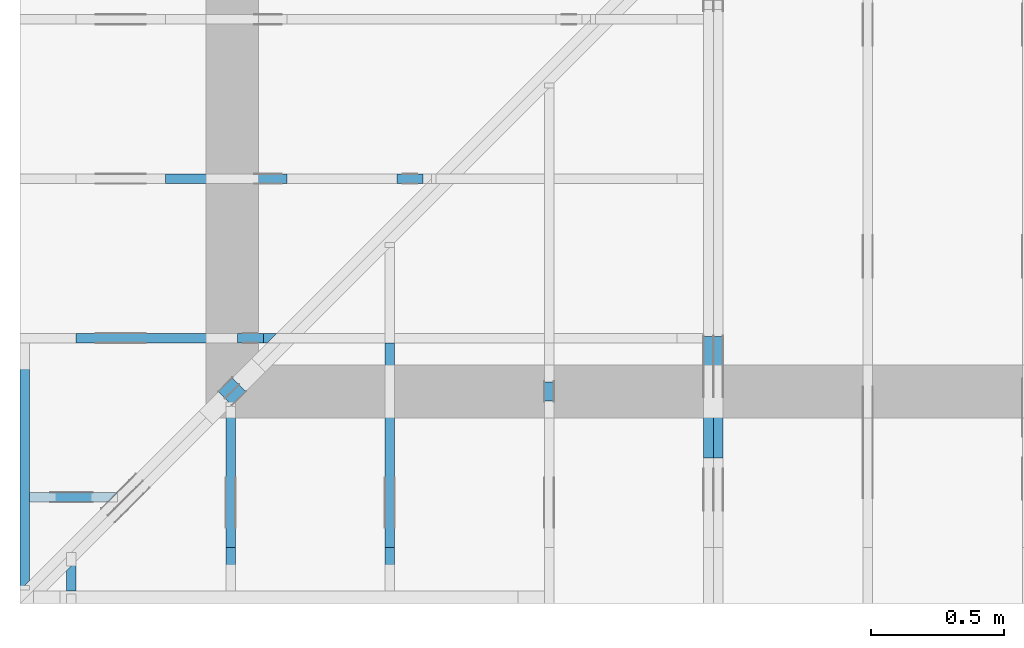
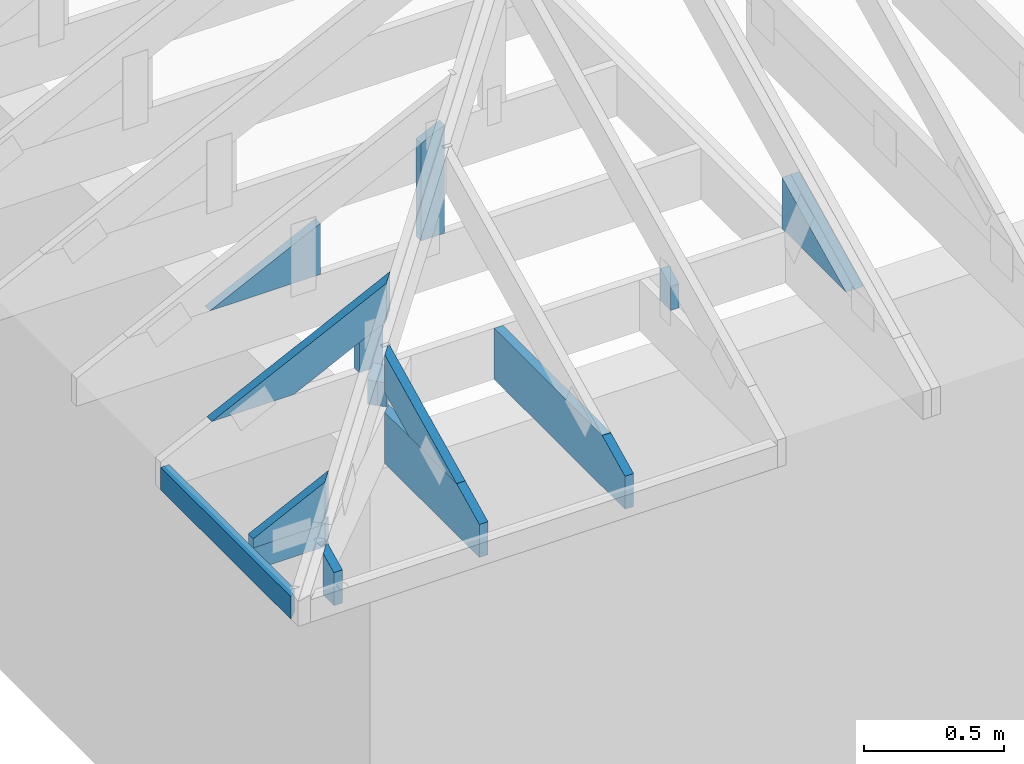
# One storey, part 41 of 159: 16 members, 10 elements without a shape of their own.
"""IFC2X3 building model written with IfcOpenShell, lengths in millimetres."""

from ifc_helpers import new_model, si_unit, frame, origin, origin_with_axes, origin_2d, place, context, project, spatial, faceted_brep, element, aggregate, save


model = new_model("IFC2X3")

# Units and contexts
model_context = context("Model", 3, precision=1e-05, world=origin())
plan_context = context("Plan", 2, precision=1e-05, world=origin_2d())
ifc_project = project(units=[si_unit("LENGTHUNIT", "METRE", prefix="MILLI"), si_unit("AREAUNIT", "SQUARE_METRE"), si_unit("VOLUMEUNIT", "CUBIC_METRE"), si_unit("SOLIDANGLEUNIT", "STERADIAN"), si_unit("PLANEANGLEUNIT", "RADIAN"), si_unit("MASSUNIT", "GRAM"), si_unit("TIMEUNIT", "SECOND"), si_unit("THERMODYNAMICTEMPERATUREUNIT", "DEGREE_CELSIUS"), si_unit("LUMINOUSINTENSITYUNIT", "LUMEN")], contexts=[model_context, plan_context])

# Site, building, storey
site_placement = place(None, origin_with_axes())
site = spatial("IfcSite", under=ifc_project, at=site_placement, CompositionType="ELEMENT")
building_placement = place(site_placement, origin_with_axes())
building = spatial("IfcBuilding", under=site, at=building_placement, Name="Plan 1", CompositionType="ELEMENT")
storey_placement = place(building_placement, origin_with_axes())
storey = spatial("IfcBuildingStorey", under=building, at=storey_placement, Name="Etasje 1", CompositionType="ELEMENT", Elevation=0.0)

# Assembly, member
assembly_1_placement = place(storey_placement, frame((-700.0000000000088, 282.0074014212605, 0.0), z_axis=(-1.0, 2.1499973025876362e-14, 6.123031769111886e-17), x_axis=(-2.1499973025876362e-14, -1.0, 0.0)))
assembly_1 = element("IfcElementAssembly", 1, at=assembly_1_placement, inside=storey, Name="uu2 (1)", AssemblyPlace="FACTORY", PredefinedType="TRUSS")
member_1_placement = place(assembly_1_placement, frame((931.0946655273438, 98.00000236466238, -36.00000106976029), z_axis=(0.0, 0.0, 1.0), x_axis=(-1.0, 1.2246063538223773e-16, 0.0)))
member_1 = element("IfcMember", 2, at=member_1_placement, Name="uu2-U53", context=model_context, shape_type="Brep", body=[
    faceted_brep([(36.00002329176911, 2.3646623104379705e-06, -2.842170943040401e-14), (2.2222008851713326e-05, 2.3646623787954017e-06, 36.00000106976023), (2.222200897250559e-05, 98.00000236466238, 36.0000010697603), (36.00002329176915, 98.00000236466232, 1.1368683772161603e-13), (931.0946877493527, 2.364662207761731e-06, 1.0697602874643055e-06), (931.0946877493527, 2.364662225953234e-06, 36.00000106976029), (2.2222008965400164e-05, 2.3646623969869005e-06, 36.00000106976029), (36.000022222008965, 2.364662372182523e-06, 1.0697602874643055e-06), (36.000022222011125, 98.00000236466238, 1.069760291872891e-06), (931.0946877493548, 98.00000236466238, 1.0697604014867523e-06), (931.0946877493548, 2.364662492482239e-06, 1.0697604014867523e-06), (36.00002222201101, 2.364662492482239e-06, 1.069760291872891e-06), (2.222201112545008e-05, 98.00000236466238, 36.00000106976029), (931.0946877493549, 98.00000236466232, 36.00000106976029), (931.0946877493549, 98.00000236466232, 1.0697602874643053e-06), (36.000022222011125, 98.00000236466238, 1.0697602874643053e-06), (931.0946655273438, 98.0000023463934, 2.0347285101252055e-06), (931.0946655273438, 98.0000023463934, 36.00000106976029), (931.0946655273438, 0.0, 36.000002896668946), (931.0946655273438, 0.0, 3.532793598992612e-06), (931.0946655273438, 98.00000236466249, 36.00000106976029), (0.0, 98.00000236466249, 36.00000106976029), (0.0, 2.364662393006256e-06, 36.00000106976029), (931.0946655273438, 2.364662393006256e-06, 36.00000106976029)], [[[0, 1, 2, 3]], [[4, 5, 6, 7]], [[8, 9, 10, 11]], [[12, 13, 14, 15]], [[16, 17, 18, 19]], [[20, 21, 22, 23]]]),
])
aggregate(assembly_1, [member_1])

# Assembly, members
assembly_2_placement = place(storey_placement, frame((-664.0000000000214, -317.99259857873943, 1.1021457184401395e-15), z_axis=(0.0, -1.0, 6.123031769111886e-17), x_axis=(1.0, 0.0, 0.0)))
assembly_2 = element("IfcElementAssembly", 3, at=assembly_2_placement, inside=storey, Name="S9 (106)", AssemblyPlace="FACTORY", PredefinedType="TRUSS")
member_2_placement = place(assembly_2_placement, frame((49.292707424058904, -3.0650545701473186, -36.000001130761554), z_axis=(0.0, 0.0, 1.0), x_axis=(0.8987940462991673, 0.43837114678907735, 0.0)))
member_2 = element("IfcMember", 4, at=member_2_placement, Name="S9-O79", context=model_context, shape_type="Brep", body=[
    faceted_brep([(385.7178019391226, 148.00000083082443, 3.1665292681282153e-06), (345.6641349417873, 147.9999951378864, 35.999998100575525), (273.4797109907065, 3.211798116353748e-07, 36.00000113076159), (313.5333809332368, -2.1316282072803006e-14, 9.131758815783542e-07), (17.34125812148463, 148.00000032034563, 1.130761553724824e-06), (17.34125812148463, 148.0000003203457, 36.000001130761554), (345.66413409804716, 148.00000032034566, 36.000001130761554), (385.7178030738772, 148.0000003203456, 1.130761553724824e-06), (1.2395862583503003e-05, 112.44517100735109, 1.2340157908852234e-06), (1.2395862583503003e-05, 112.44517100735109, 36.00000113076156), (17.341261635190712, 148.00000094052962, 36.00000085956592), (17.341261635190712, 148.00000094052962, 7.888609052210118e-31), (230.54677531017086, 3.214345412061448e-07, 1.130761553724824e-06), (230.54677531017086, 3.214345412061448e-07, 36.000001130761554), (1.3192543747209129e-05, 112.44516939454279, 36.000001130761554), (1.3192543747209129e-05, 112.44516939454279, 1.130761553724824e-06), (313.5333808476825, 3.2094196696327795e-07, 1.130761553724824e-06), (273.4797118718524, 3.209419845186718e-07, 36.000001130761554), (230.54677806447938, 3.209419924050633e-07, 36.000001130761554), (230.54677806447938, 3.209419822071661e-07, 1.130761553724824e-06), (345.6641363447104, 148.0000003211798, 36.000001130761554), (17.341252738753383, 148.0000003211798, 36.000001130761554), (5.180159625695069e-06, 112.44516786268372, 36.000001130761554), (230.54677718333346, 3.214346548929825e-07, 36.000001130761554), (273.4797109907065, 3.214346548929825e-07, 36.000001130761554), (17.34124755859377, 148.00000032137, 1.1307615558484441e-06), (385.7178039550782, 148.00000032137, 1.1307616009600713e-06), (313.5333786010743, 3.202207068397911e-07, 1.1307615921203207e-06), (230.54676818847656, 3.202207068397911e-07, 1.1307615819577276e-06), (0.0, 112.4451716764219, 1.130761553724824e-06)], [[[0, 1, 2, 3]], [[4, 5, 6, 7]], [[8, 9, 10, 11]], [[12, 13, 14, 15]], [[16, 17, 18, 19]], [[20, 21, 22, 23, 24]], [[25, 26, 27, 28, 29]]]),
])
member_3_placement = place(assembly_2_placement, frame((331.09464437508007, 98.00000236466187, -36.000001069767535), z_axis=(0.0, 0.0, 1.0), x_axis=(-1.0, 1.898817474782488e-15, 0.0)))
member_3 = element("IfcMember", 5, at=member_3_placement, Name="S9-U56", context=model_context, shape_type="Brep", body=[
    faceted_brep([(2.2609328924537968e-14, 2.364661862731428e-06, -2.2609328924528657e-14), (36.00000106975323, 2.364661938258905e-06, 36.000001069767535), (36.00000106975305, 98.00000236466194, 36.00000106976755), (4.060030872416688e-14, 98.00000236466187, 2.0098422143426072e-13), (331.09463607951886, 2.3646618916506707e-06, 1.06976753500021e-06), (331.09463607951886, 2.3646618778677506e-06, 36.000001069767535), (36.00000106975324, 2.3646619320739654e-06, 36.000001069767535), (1.0697532388803666e-06, 2.36466195246976e-06, 1.06976753500021e-06), (1.0697676202653383e-06, 98.00000236466187, 1.06976753500021e-06), (36.00000106976762, 98.00000236466187, 36.000001069767535), (331.09463607953325, 98.00000236466184, 36.000001069767535), (331.09463607953325, 98.00000236466185, 1.06976753500021e-06), (331.09464437508007, 98.0000023463934, 2.0347357576611103e-06), (331.09464437508007, 98.0000023463934, 36.000001069767535), (331.09464437508007, 0.0, 36.00000289667619), (331.09464437508007, 0.0, 3.5328008465285166e-06), (331.0946360795187, 98.00000236466249, 36.000001069767535), (36.00000106975307, 98.00000236466249, 36.000001069767535), (36.00000106975324, 2.364661938258905e-06, 36.000001069767535), (331.0946360795187, 2.364661938258905e-06, 36.000001069767535), (9.365314269871305e-06, 98.00000236466187, 1.069767535000211e-06), (331.0946443750799, 98.00000236466187, 1.0697675755462705e-06), (331.09464437508007, 2.364662492482239e-06, 1.0697675755462705e-06), (9.365314269871305e-06, 2.364662492482239e-06, 1.069767535000211e-06)], [[[0, 1, 2, 3]], [[4, 5, 6, 7]], [[8, 9, 10, 11]], [[12, 13, 14, 15]], [[16, 17, 18, 19]], [[20, 21, 22, 23]]]),
])
aggregate(assembly_2, [member_2, member_3])

assembly_3_placement = place(storey_placement, frame((111.02226140474966, -663.9989301294845, 1.1021457184401395e-15), z_axis=(1.0, -6.123031769111886e-17, 6.123031769111886e-17), x_axis=(6.123031769111886e-17, 1.0, 0.0)))
assembly_3 = element("IfcElementAssembly", 6, at=assembly_3_placement, inside=storey, Name="S10 (29)", AssemblyPlace="FACTORY", PredefinedType="TRUSS")
member_4_placement = place(assembly_3_placement, frame((240.06020039916442, 89.97846894973709, -36.000000217580755), z_axis=(0.0, 0.0, 1.0), x_axis=(0.8987940462991671, 0.43837114678907757, 0.0)))
member_4 = element("IfcMember", 7, at=member_4_placement, Name="S10-O75", context=model_context, shape_type="Brep", body=[
    faceted_brep([(610.7398079717809, 147.99999481670355, 36.000003247777414), (538.5553840206942, -2.842170943040401e-14, 36.00000021758072), (498.50171407815947, 3.211861638874325e-07, -2.842170943040401e-14), (570.6861380292462, 147.9999951378899, 3.0301966660317703e-06), (-4.7331654114344296e-30, 148.0000000009527, 2.1758074808531092e-07), (-1.4419777277064443e-30, 148.00000000095275, 36.00000021758075), (610.7398071289062, 148.00000000095272, 36.00000021758075), (570.6861381530764, 148.00000000095267, 2.1758074808531092e-07), (4.10803670547466e-05, 148.0000000001541, 2.1758074808531594e-07), (570.6861372717733, 148.0000000001541, 2.1758081797189788e-07), (498.50171191776934, 9.003429113363381e-10, 2.175808091321473e-07), (303.4449873694295, 9.003429113363381e-10, 2.1758078524537688e-07), (303.44499637942886, 5.7411853049416095e-12, 2.1758074808531092e-07), (303.44499637942886, 5.7411853049416095e-12, 36.00000021758075), (2.4666297598230358e-05, 148.00000154094596, 36.00000021758075), (2.4666297598230358e-05, 148.00000154094596, 2.1758074808531092e-07), (538.5553831394172, 8.696146604722728e-13, 36.00000021758075), (303.4449972446418, 9.128023113347287e-13, 36.00000021758075), (303.4449972446418, 9.105980198978485e-13, 2.1758074808531092e-07), (498.5017141635872, 8.747678656636475e-13, 2.1758074808531092e-07), (610.7398093746981, 148.0, 36.00000021758075), (2.5133975327662483e-05, 148.0, 36.00000021758075), (303.445001940616, 5.7980287238024175e-12, 36.00000021758075), (538.5553840206942, 5.7980287238024175e-12, 36.00000021758075)], [[[0, 1, 2, 3]], [[4, 5, 6, 7]], [[8, 9, 10, 11]], [[12, 13, 14, 15]], [[16, 17, 18, 19]], [[20, 21, 22, 23]]]),
])
member_5_placement = place(assembly_3_placement, frame((724.110595703125, 223.00000249095513, -36.00000106976019), z_axis=(0.0, 0.0, 1.0), x_axis=(-1.0, 1.2246063538223773e-16, 0.0)))
member_5 = element("IfcMember", 8, at=member_5_placement, Name="S10-U28", context=model_context, shape_type="Brep", body=[
    faceted_brep([(36.00002361355904, 2.4909551213138114e-06, 2.1316282072803006e-14), (2.2543798877450172e-05, 2.4909551257223943e-06, 36.00000106976019), (2.2543798891661027e-05, 223.00000249095513, 36.0000010697602), (36.00002361355907, 223.00000249095513, 1.4210854715202004e-14), (548.9292827977051, 2.4909550248890507e-06, 1.0697601879883223e-06), (548.9292827977051, 2.490955027093342e-06, 36.00000106976019), (2.2543798877450172e-05, 2.490955127926681e-06, 36.00000106976019), (36.00002254379888, 2.4909551191095153e-06, 1.0697601879883223e-06), (36.00002254379979, 223.00000249095513, 1.069760192396908e-06), (712.1106182469248, 223.00000249095513, 1.069760275193841e-06), (712.1106182469248, 79.588839160877, 1.069760275193841e-06), (548.929282797706, 2.4909551825658127e-06, 1.069760255210551e-06), (36.00002254379979, 2.4909551825658127e-06, 1.069760192396908e-06), (2.2543799786944874e-05, 223.00000249095513, 36.00000106976019), (712.1106182469248, 223.00000249095507, 36.00000106976019), (712.1106182469248, 223.00000249095507, 1.0697601879883223e-06), (36.00002254379979, 223.00000249095513, 1.0697601879883223e-06), (712.110595703125, 79.58883824035215, 1.0697601879883223e-06), (712.110595703125, 79.58883824035215, 36.00000106976019), (548.929294912301, 8.526512829121202e-14, 36.00000106976019), (548.929294912301, 8.526512829121202e-14, 1.0697601879883223e-06), (712.110595703125, 223.00000308164468, 2.031961024329121e-06), (712.110595703125, 223.00000308164468, 36.00000106976019), (712.110595703125, 79.58883257120797, 36.00000360334501), (712.110595703125, 79.58883257120797, 3.8689653223400455e-06), (712.110595703125, 223.00000157043016, 36.00000106976019), (0.0, 223.00000157043016, 36.00000106976019), (0.0, 1.5704301290497824e-06, 36.00000106976019), (548.9293060302734, 1.5704301290497824e-06, 36.00000106976019), (712.110595703125, 79.58883824035203, 36.00000106976019)], [[[0, 1, 2, 3]], [[4, 5, 6, 7]], [[8, 9, 10, 11, 12]], [[13, 14, 15, 16]], [[17, 18, 19, 20]], [[21, 22, 23, 24]], [[25, 26, 27, 28, 29]]]),
])
aggregate(assembly_3, [member_4, member_5])

# Assembly, member
assembly_4_placement = place(storey_placement, frame((711.0222614047476, -663.9989301294845, 1.1021457184401395e-15), z_axis=(1.0, 1.6081428723391245e-16, 6.123031769111886e-17), x_axis=(-1.6081428723391245e-16, 1.0, 0.0)))
assembly_4 = element("IfcElementAssembly", 9, at=assembly_4_placement, inside=storey, Name="S11 (28)", AssemblyPlace="FACTORY", PredefinedType="TRUSS")
member_6_placement = place(assembly_4_placement, frame((946.00634765625, 223.0, -36.0), z_axis=(0.0, 0.0, 1.0), x_axis=(-1.0, 1.2246063538223773e-16, 0.0)))
member_6 = element("IfcMember", 10, at=member_6_placement, Name="S11-U23", context=model_context, shape_type="Brep", body=[
    faceted_brep([(934.00634765625, 223.0000000000001, 36.0), (0.0, 223.0000000000001, 36.0), (0.0, 0.0, 36.0), (770.8250579833984, 0.0, 36.0), (934.00634765625, 79.58883666992199, 36.0), (0.0, 223.0000000000001, 0.0), (934.00634765625, 223.0000000000001, 1.143790107850276e-13), (934.00634765625, 79.58883666992199, 1.143790107850276e-13), (770.8250579833984, 0.0, 9.439572636919721e-14), (0.0, 0.0, 0.0), (1.6105505096675188e-05, 0.0, 0.0), (1.610550509887948e-05, -2.6993892992798474e-31, 36.0), (1.61055051261882e-05, 223.0, 36.0), (1.610550512398391e-05, 223.0, -1.6721217180559947e-30), (770.8250519726425, -1.415935902311914e-13, 1.3890631406126874e-29), (770.8250519726425, -1.3938929879431113e-13, 36.0), (1.6105505096675188e-05, 2.2042866969276293e-15, 36.0), (1.6105505096675188e-05, -4.739952649485818e-21, 2.902288065688772e-37), (934.0063476562502, 79.58883574852348, 2.524354896707238e-29), (934.0063476562502, 79.58883574852348, 36.0), (770.8250519726427, -2.2737367544323206e-13, 36.0), (770.8250519726427, -2.2737367544323206e-13, 1.5777218104420236e-29), (934.00634765625, 223.0000000000001, 0.0), (934.00634765625, 223.0000000000001, 36.0), (934.00634765625, 79.58883574852382, 36.0), (934.00634765625, 79.58883574852382, 0.0), (1.6105505096675188e-05, 223.0, 0.0), (1.6105505096675188e-05, 223.0, 36.0), (934.00634765625, 223.00000000000014, 36.0), (934.00634765625, 223.00000000000014, 3.1554436208840472e-30)], [[[0, 1, 2, 3, 4]], [[5, 6, 7, 8, 9]], [[10, 11, 12, 13]], [[14, 15, 16, 17]], [[18, 19, 20, 21]], [[22, 23, 24, 25]], [[26, 27, 28, 29]]]),
])
aggregate(assembly_4, [member_6])

assembly_5_placement = place(storey_placement, frame((1311.0222614047498, -699.9989301294839, 1.1021457184401395e-15), z_axis=(1.0, -6.123031769111886e-17, 6.123031769111886e-17), x_axis=(6.123031769111886e-17, 1.0, 0.0)))
assembly_5 = element("IfcElementAssembly", 11, at=assembly_5_placement, inside=storey, Name="S12 (27)", AssemblyPlace="FACTORY", PredefinedType="TRUSS")
member_7_placement = place(assembly_5_placement, frame((762.5, 362.83549055598763, -36.0), z_axis=(0.0, 0.0, 1.0), x_axis=(-1.836909530733566e-16, -1.0, 0.0)))
member_7 = element("IfcMember", 12, at=member_7_placement, Name="S12-D72", context=model_context, shape_type="Brep", body=[
    faceted_brep([(139.8354905559876, 73.00000000000011, 36.0), (1.0819659451044572e-05, 73.00000000000011, 36.0), (35.60447248958138, 0.0, 36.0), (139.8354905559876, 0.0, 36.0), (1.0819659451044572e-05, 73.00000000000011, 1.3249823709943517e-21), (139.8354905559876, 73.00000000000011, 1.7124343022473146e-14), (139.8354905559876, 0.0, 1.7124343022473146e-14), (35.60447248958138, 0.0, 4.36014632352354e-15), (35.604478965349074, -1.7763568394002505e-15, 0.0), (35.604478965349074, 0.0, 36.0), (1.0658141036401503e-14, 73.0, 36.0), (7.105427357601002e-15, 73.0, -3.944304526105059e-31), (139.8354905559876, 5.967783702888701e-14, 3.306988270595656e-30), (139.8354905559876, 6.188212846576729e-14, 36.0), (35.604478965349074, -1.1547312833667005e-14, 36.0), (35.604478965349074, -1.3751604270547285e-14, 8.420150982481572e-31), (139.8354905559876, 73.00000000000011, 0.0), (139.8354905559876, 73.00000000000011, 36.0), (139.8354905559876, 1.1368683772161603e-13, 36.0), (139.8354905559876, 1.1368683772161603e-13, 0.0), (0.0, 73.0, 0.0), (0.0, 73.0, 36.0), (139.8354905559876, 73.00000000000014, 36.0), (139.8354905559876, 73.00000000000014, 1.5777218104420236e-30)], [[[0, 1, 2, 3]], [[4, 5, 6, 7]], [[8, 9, 10, 11]], [[12, 13, 14, 15]], [[16, 17, 18, 19]], [[20, 21, 22, 23]]]),
])
aggregate(assembly_5, [member_7])

# Assembly, members
assembly_6_placement = place(storey_placement, frame((-700.000000000007, 282.0074014212605, 1.1021457184401395e-15), z_axis=(0.0, -1.0, 6.123031769111886e-17), x_axis=(1.0, 0.0, 0.0)))
assembly_6 = element("IfcElementAssembly", 13, at=assembly_6_placement, inside=storey, Name="S8 (22)", AssemblyPlace="FACTORY", PredefinedType="TRUSS")
member_8_placement = place(assembly_6_placement, frame((276.06022271001683, 89.97847947377899, -36.00000021758524), z_axis=(0.0, 0.0, 1.0), x_axis=(0.898794046299167, 0.4383711467890774, 0.0)))
member_8 = element("IfcMember", 14, at=member_8_placement, Name="S8-O72", context=model_context, shape_type="Brep", body=[
    faceted_brep([(841.0306585374417, 148.0000008308218, 2.2533284322889813e-06), (800.9769915401059, 147.99999513789155, 35.99999718737422), (728.7925675890198, 3.2118751391863043e-07, 36.000000217585296), (768.8462375315506, -5.684341886080802e-14, 5.684341886080802e-14), (9.511128951089631e-07, 148.00000032208916, 2.1758523871540092e-07), (9.511128951089631e-07, 148.00000032208916, 36.00000021758524), (800.9769906972067, 148.0000003220891, 36.00000021758524), (841.0306596730368, 148.0000003220891, 2.1758523871540092e-07), (303.4449717131314, 3.2149365836176e-07, 2.1758523871540092e-07), (303.4449717131314, 3.2149365836176e-07, 36.00000021758524), (1.4210854715202004e-14, 148.00000186243395, 36.00000021758524), (1.4210854715202004e-14, 148.00000186243395, 2.1758523871540092e-07), (768.846237446114, 3.2115863834029817e-07, 2.1758523871540092e-07), (728.7925684702841, 3.211585919468458e-07, 36.00000021758524), (303.44496181134826, 3.2115867007935306e-07, 36.00000021758524), (303.44496181134826, 3.2115872383030206e-07, 2.1758523871540092e-07), (800.9769929430238, 148.0000003211876, 36.00000021758524), (2.6085113404406002e-05, 148.0000003211876, 36.00000021758524), (303.44497237417585, 3.214938431028713e-07, 36.00000021758524), (728.7925675890197, 3.214938431028713e-07, 36.00000021758524), (2.090588856162867e-05, 148.0000003216421, 2.175852387154035e-07), (841.0306605543262, 148.0000003216421, 2.1758534170855e-07), (768.8462352003223, 3.2211147527050343e-07, 2.175853328687994e-07), (303.44496719495106, 3.2211147527050343e-07, 2.175852758754644e-07)], [[[0, 1, 2, 3]], [[4, 5, 6, 7]], [[8, 9, 10, 11]], [[12, 13, 14, 15]], [[16, 17, 18, 19]], [[20, 21, 22, 23]]]),
])
member_9_placement = place(assembly_6_placement, frame((819.0946433071368, 402.6318664550781, -36.0), z_axis=(0.0, 0.0, 1.0), x_axis=(-1.836909530733566e-16, -1.0, 0.0)))
member_9 = element("IfcMember", 15, at=member_9_placement, Name="S8-S13", context=model_context, shape_type="Brep", body=[
    faceted_brep([(179.63186645507812, 98.00002222020703, 36.0), (0.0, 98.00002222020703, 36.0), (47.79779052734375, 2.222020691533544e-05, 36.0), (179.63186645507815, 2.222020691533544e-05, 36.0), (0.0, 98.00002222020703, 0.0), (179.63186645507812, 98.00002222020703, 2.1997832500986142e-14), (179.63186645507815, 2.222020691533544e-05, 2.1997832500986145e-14), (47.79779052734375, 2.222020691533544e-05, 5.853347797845619e-15), (47.79780298577679, 2.8983038191654487e-11, 3.2986348880323867e-31), (47.7978029857768, 2.8983038191654487e-11, 36.0), (9.306320890800635e-06, 98.00000000001447, 36.0), (9.306320890800635e-06, 98.00000000001447, -2.0951596753939216e-30), (179.63186645507815, -9.937330263649128e-14, 6.084658890448049e-30), (179.63186645507815, -9.7169011199611e-14, 36.0), (47.7978029857768, 2.89659059119595e-11, 36.0), (47.7978029857768, 2.896370162052262e-11, 1.6190519678979605e-30), (179.63186645507815, 98.00000000001455, 1.5777218104420236e-30), (179.63186645507815, 98.00000000001455, 36.0), (179.63186645507815, 0.0, 36.0), (179.63186645507815, 0.0, 0.0), (9.306320862378925e-06, 98.00000000001444, 0.0), (9.306320862378925e-06, 98.00000000001444, 36.0), (179.63186645507812, 98.00000000001458, 36.0), (179.63186645507812, 98.00000000001458, 2.3665827156630354e-30)], [[[0, 1, 2, 3]], [[4, 5, 6, 7]], [[8, 9, 10, 11]], [[12, 13, 14, 15]], [[16, 17, 18, 19]], [[20, 21, 22, 23]]]),
])
aggregate(assembly_6, [member_8, member_9])

assembly_7_placement = place(storey_placement, frame((-700.000000000007, 882.0074014212605, 1.1021457184401395e-15), z_axis=(0.0, -1.0, 6.123031769111886e-17), x_axis=(1.0, 0.0, 0.0)))
assembly_7 = element("IfcElementAssembly", 16, at=assembly_7_placement, inside=storey, Name="S7 (20)", AssemblyPlace="FACTORY", PredefinedType="TRUSS")
member_10_placement = place(assembly_7_placement, frame((1419.0946044921875, 695.2714233398438, -36.0), z_axis=(0.0, 0.0, 1.0), x_axis=(-1.836909530733566e-16, -1.0, 0.0)))
member_10 = element("IfcMember", 17, at=member_10_placement, Name="S7-S12", context=model_context, shape_type="Brep", body=[
    faceted_brep([(472.2714233398437, 98.00000000000023, 36.0), (0.0, 98.00000000000023, 36.0), (47.79779052734375, 0.0, 36.0), (472.27142333984375, 0.0, 36.0), (0.0, 98.00000000000023, 0.0), (472.2714233398437, 98.00000000000023, 5.783465857507103e-14), (472.27142333984375, 0.0, 5.783465857507104e-14), (47.79779052734375, 0.0, 5.853347797845619e-15), (47.79780673151253, 3.881496376934024e-05, 6.456686136436451e-32), (47.79780673151254, 3.881496376934024e-05, 36.0), (1.305208573398886e-05, 98.00003881496377, 36.0), (1.305208573398886e-05, 98.00003881496377, -1.849144953154041e-30), (472.27142333984375, 3.8814963660537575e-05, 2.080171767949591e-29), (472.27142333984375, 3.881496366274187e-05, 36.0), (47.79780673151254, 3.881496374071383e-05, 36.0), (47.79780673151254, 3.881496373850954e-05, 2.1053073730571788e-30), (472.27142333984375, 98.000038814964, 6.310887241768095e-30), (472.27142333984375, 98.000038814964, 36.0), (472.27142333984375, 3.881496400026663e-05, 36.0), (472.27142333984375, 3.881496400026663e-05, 0.0), (1.3052085705567151e-05, 98.00003881496377, 0.0), (1.3052085705567151e-05, 98.00003881496377, 36.0), (472.2714233398437, 98.00003881496396, 36.0), (472.2714233398437, 98.00003881496396, -3.1554436208840472e-30)], [[[0, 1, 2, 3]], [[4, 5, 6, 7]], [[8, 9, 10, 11]], [[12, 13, 14, 15]], [[16, 17, 18, 19]], [[20, 21, 22, 23]]]),
])
member_11_placement = place(assembly_7_placement, frame((1006.012513198547, 446.0, -36.0), z_axis=(0.0, 0.0, 1.0), x_axis=(-1.0, 3.940295897723878e-13, 0.0)))
member_11 = element("IfcMember", 18, at=member_11_placement, Name="S7-KI3", context=model_context, shape_type="Brep", body=[
    faceted_brep([(9.914278962241951e-07, 223.00000000000003, 36.0), (9.91515776149754e-07, 0.0, 36.0), (457.2177744289279, 223.0000000001802, 36.0), (9.914278962241951e-07, 223.00000000000003, 0.0), (457.2177744289279, 223.0000000001802, 0.0), (9.91515776149754e-07, 0.0, 0.0), (8.787992555880918e-11, -5.877471754111438e-39, 7.174648137343064e-43), (8.788212985024606e-11, 8.680161727469901e-28, 36.0), (6.814877438404889e-14, 223.00000000000003, 36.0), (6.594448294716861e-14, 223.00000000000003, -4.037801640831852e-30), (457.2177566741944, 223.00000000018008, 9.610437011546742e-30), (457.2177566741944, 223.00000000018008, 36.0), (8.787895926104415e-11, 1.981204019761577e-15, 36.0), (8.787992555880919e-11, -1.2924697071141057e-26, 7.174648137343064e-43), (0.0, 223.00000000000003, 0.0), (0.0, 223.00000000000003, 36.0), (457.21775667419433, 223.0000000001802, 36.0), (457.21775667419433, 223.0000000001802, 0.0)], [[[0, 1, 2]], [[3, 4, 5]], [[6, 7, 8, 9]], [[10, 11, 12, 13]], [[14, 15, 16, 17]]]),
])
aggregate(assembly_7, [member_10, member_11])

assembly_8_placement = place(storey_placement, frame((-674.5441558772914, -725.4547742521996, 2.204291436880279e-15), z_axis=(0.7071067811865475, -0.7071067811865476, 6.123031769111886e-17), x_axis=(0.7071067811865476, 0.7071067811865475, 0.0)))
assembly_8 = element("IfcElementAssembly", 19, at=assembly_8_placement, inside=storey, Name="GR1 (8)", AssemblyPlace="FACTORY", PredefinedType="TRUSS")
member_12_placement = place(assembly_8_placement, frame((1093.4566363361005, 353.3163288766036, -36.0), z_axis=(0.0, 0.0, 1.0), x_axis=(-1.836909530733566e-16, -1.0, 0.0)))
member_12 = element("IfcMember", 20, at=member_12_placement, Name="GR1-D75", context=model_context, shape_type="Brep", body=[
    faceted_brep([(130.31632887660362, 73.00002870296203, 36.0), (1.4179337995301466e-05, 73.00002870296203, 36.0), (25.176161640275495, 2.870296202672762e-05, 36.0), (130.31632887660365, 2.870296202672762e-05, 36.0), (1.4179337995301466e-05, 73.00002870296203, 1.7364107402041225e-21), (130.31632887660362, 73.00002870296203, 1.5958620434909532e-14), (130.31632887660365, 2.870296202672762e-05, 1.5958620434909535e-14), (25.176161640275495, 2.870296202672762e-05, 3.0830887509540575e-15), (25.17616851694908, 0.0, -1.9721522630525295e-31), (25.176168516949083, 8.881784197001252e-16, 36.0), (1.7763568394002505e-14, 73.00000000000001, 36.0), (1.4210854715202004e-14, 73.00000000000001, -9.860761315262648e-31), (130.31632887660365, -2.3937930652364306e-14, 1.4657270987122386e-30), (130.31632887660365, -2.1733639215484027e-14, 36.0), (25.176168516949076, -2.4203429527335313e-15, 36.0), (25.176168516949076, -4.62463438961381e-15, 2.831678328813272e-31), (130.31632887660365, 73.0, 1.5777218104420236e-30), (130.31632887660365, 73.0, 36.0), (130.31632887660365, 0.0, 36.0), (130.31632887660365, 0.0, 0.0), (0.0, 73.0, 0.0), (-1.3496946496399237e-31, 73.0, 36.0), (130.31632887660362, 72.99999999999999, 36.0), (130.31632887660362, 72.99999999999999, -7.888609052210118e-31)], [[[0, 1, 2, 3]], [[4, 5, 6, 7]], [[8, 9, 10, 11]], [[12, 13, 14, 15]], [[16, 17, 18, 19]], [[20, 21, 22, 23]]]),
])
member_13_placement = place(assembly_8_placement, frame((1093.4566363361005, 353.3163288766036, -72.0), z_axis=(0.0, 0.0, 1.0), x_axis=(-1.836909530733566e-16, -1.0, 0.0)))
member_13 = element("IfcMember", 21, at=member_13_placement, Name="GR1-D75", context=model_context, shape_type="Brep", body=[
    faceted_brep([(130.31632887660362, 73.00002870296203, 36.0), (1.4179337995301466e-05, 73.00002870296203, 36.0), (25.176161640275495, 2.870296202672762e-05, 36.0), (130.31632887660365, 2.870296202672762e-05, 36.0), (1.4179337995301466e-05, 73.00002870296203, 1.7364107402041225e-21), (130.31632887660362, 73.00002870296203, 1.5958620434909532e-14), (130.31632887660365, 2.870296202672762e-05, 1.5958620434909535e-14), (25.176161640275495, 2.870296202672762e-05, 3.0830887509540575e-15), (25.17616851694908, 0.0, -1.9721522630525295e-31), (25.176168516949083, 8.881784197001252e-16, 36.0), (1.7763568394002505e-14, 73.00000000000001, 36.0), (1.4210854715202004e-14, 73.00000000000001, -9.860761315262648e-31), (130.31632887660365, -2.3937930652364306e-14, 1.4657270987122386e-30), (130.31632887660365, -2.1733639215484027e-14, 36.0), (25.176168516949076, -2.4203429527335313e-15, 36.0), (25.176168516949076, -4.62463438961381e-15, 2.831678328813272e-31), (130.31632887660365, 73.0, 1.5777218104420236e-30), (130.31632887660365, 73.0, 36.0), (130.31632887660365, 0.0, 36.0), (130.31632887660365, 0.0, 0.0), (0.0, 73.0, 0.0), (-1.3496946496399237e-31, 73.0, 36.0), (130.31632887660362, 72.99999999999999, 36.0), (130.31632887660362, 72.99999999999999, -7.888609052210118e-31)], [[[0, 1, 2, 3]], [[4, 5, 6, 7]], [[8, 9, 10, 11]], [[12, 13, 14, 15]], [[16, 17, 18, 19]], [[20, 21, 22, 23]]]),
])
aggregate(assembly_8, [member_12, member_13])

assembly_9_placement = place(storey_placement, frame((1875.0222614047502, 9699.999999999993, 0.0), z_axis=(-1.0, 1.836909530733566e-16, 6.123031769111886e-17), x_axis=(-1.836909530733566e-16, -1.0, 0.0)))
assembly_9 = element("IfcElementAssembly", 22, at=assembly_9_placement, inside=storey, Name="V1 (2)", AssemblyPlace="FACTORY", PredefinedType="TRUSS")
member_14_placement = place(assembly_9_placement, frame((9393.986328124978, 223.0, -36.0), z_axis=(0.0, 0.0, 1.0), x_axis=(1.0, -9.350365533927762e-14, 0.0)))
member_14 = element("IfcMember", 23, at=member_14_placement, Name="V1-KI3", context=model_context, shape_type="Brep", body=[
    faceted_brep([(0.0, 222.99999999999997, 36.0), (2.1827872842550278e-11, 0.0, 36.0), (457.2177734375218, 4.274625098332763e-11, 36.0), (0.0, 222.99999999999997, 0.0), (457.2177734375218, 4.274625098332763e-11, 0.0), (2.1827872842550278e-11, 0.0, 0.0), (8.881103531166445e-05, 0.0, 0.0), (8.881103531386875e-05, 2.150878561891665e-28, 36.0), (8.881101355416083e-05, 222.99999999999997, 36.0), (8.881101355195654e-05, 222.99999999999997, -4.173760271069185e-30), (457.21784548277355, 4.255556237832691e-11, 1.1675923864270253e-29), (457.21784548277355, 4.255776666976379e-11, 36.0), (8.881103531166445e-05, 2.204254397091479e-15, 36.0), (8.881103531166445e-05, -3.703978879995195e-20, 2.267958035433012e-36), (8.881101348379161e-05, 223.0, 1.5777218104420236e-30), (8.881101348379161e-05, 223.0, 36.0), (457.21784548277355, 4.277467269275803e-11, 36.0), (457.21784548277355, 4.277467269275803e-11, 3.1554436208840472e-30)], [[[0, 1, 2]], [[3, 4, 5]], [[6, 7, 8, 9]], [[10, 11, 12, 13]], [[14, 15, 16, 17]]]),
])
member_15_placement = place(assembly_9_placement, frame((9393.986328124978, 223.0, -72.0), z_axis=(0.0, 0.0, 1.0), x_axis=(1.0, -9.350365533927762e-14, 0.0)))
member_15 = element("IfcMember", 24, at=member_15_placement, Name="V1-KI3", context=model_context, shape_type="Brep", body=[
    faceted_brep([(0.0, 222.99999999999997, 36.0), (2.1827872842550278e-11, 0.0, 36.0), (457.2177734375218, 4.274625098332763e-11, 36.0), (0.0, 222.99999999999997, 0.0), (457.2177734375218, 4.274625098332763e-11, 0.0), (2.1827872842550278e-11, 0.0, 0.0), (8.881103531166445e-05, 0.0, 0.0), (8.881103531386875e-05, 2.150878561891665e-28, 36.0), (8.881101355416083e-05, 222.99999999999997, 36.0), (8.881101355195654e-05, 222.99999999999997, -4.173760271069185e-30), (457.21784548277355, 4.255556237832691e-11, 1.1675923864270253e-29), (457.21784548277355, 4.255776666976379e-11, 36.0), (8.881103531166445e-05, 2.204254397091479e-15, 36.0), (8.881103531166445e-05, -3.703978879995195e-20, 2.267958035433012e-36), (8.881101348379161e-05, 223.0, 1.5777218104420236e-30), (8.881101348379161e-05, 223.0, 36.0), (457.21784548277355, 4.277467269275803e-11, 36.0), (457.21784548277355, 4.277467269275803e-11, 3.1554436208840472e-30)], [[[0, 1, 2]], [[3, 4, 5]], [[6, 7, 8, 9]], [[10, 11, 12, 13]], [[14, 15, 16, 17]]]),
])
aggregate(assembly_9, [member_14, member_15])

# Assembly, member
assembly_10_placement = place(storey_placement, frame((-488.9777385952507, -663.9989301294845, 137.55837318837067), z_axis=(1.0, -6.123031769111886e-17, 6.123031769111886e-17), x_axis=(6.123031769111886e-17, 1.0, 0.0)))
assembly_10 = element("IfcElementAssembly", 25, at=assembly_10_placement, inside=storey, Name="o1 (34)", AssemblyPlace="FACTORY", PredefinedType="TRUSS")
member_16_placement = place(assembly_10_placement, frame((33.54420612937522, -181.7293775655447, -36.000001021749014), z_axis=(0.0, 0.0, 1.0), x_axis=(0.8987940462992283, 0.4383711467889517, 0.0)))
member_16 = element("IfcMember", 26, at=member_16_placement, Name="o1-O1", context=model_context, shape_type="Brep", body=[
    faceted_brep([(187.60124922743796, 178.0420937863007, 36.00000304623017), (100.76431569901756, 1.396696092115235e-10, 36.000001021749036), (68.40772975933083, 15.781361417651118, 7.17785219706002e-07), (147.54757633983053, 178.04209313394398, 6.080874719316398e-07), (62.866803756954376, 178.04209470177813, 1.0217490142849783e-06), (62.866803756954376, 178.04209470177813, 36.000001021749014), (187.60124742150515, 178.04209470177813, 36.000001021749014), (147.5475784456751, 178.04209470177813, 1.0217490142849783e-06), (62.86680669096134, 178.04209470324366, 1.0217490219836875e-06), (147.54757756498478, 178.04209470324366, 1.0217490323537484e-06), (68.40773076322697, 15.781367773537795, 1.0217490226622324e-06), (6.606878955039974e-07, 49.14603757334248, 1.0217490142849783e-06), (-1.0658141036401503e-14, 49.14604048906859, 5.299564165284209e-07), (-7.105427357601002e-15, 49.14604048906859, 36.000001021749014), (62.86680487797539, 178.04209203824342, 35.99999979520675), (62.86680487797539, 178.04209203824342, 2.5637979419682884e-30), (100.76431569930365, -7.815970093361102e-14, 36.000001021749014), (3.262029437678393e-07, 49.14604037238992, 36.00000102174901), (3.262029331096983e-07, 49.14604037238989, 1.0217490142849783e-06), (68.40773003258433, 15.781361284510648, 1.0217490142849783e-06), (187.60124502030664, 178.0420989991631, 36.000001021749014), (62.866805170453105, 178.0420989991631, 36.000001021749014), (2.954876933358719e-06, 49.14604187025685, 36.000001021749014), (100.76431569901754, 1.396642801410053e-10, 36.000001021749014)], [[[0, 1, 2, 3]], [[4, 5, 6, 7]], [[8, 9, 10, 11]], [[12, 13, 14, 15]], [[16, 17, 18, 19]], [[20, 21, 22, 23]]]),
])
aggregate(assembly_10, [member_16])

save(model, "model.ifc")
